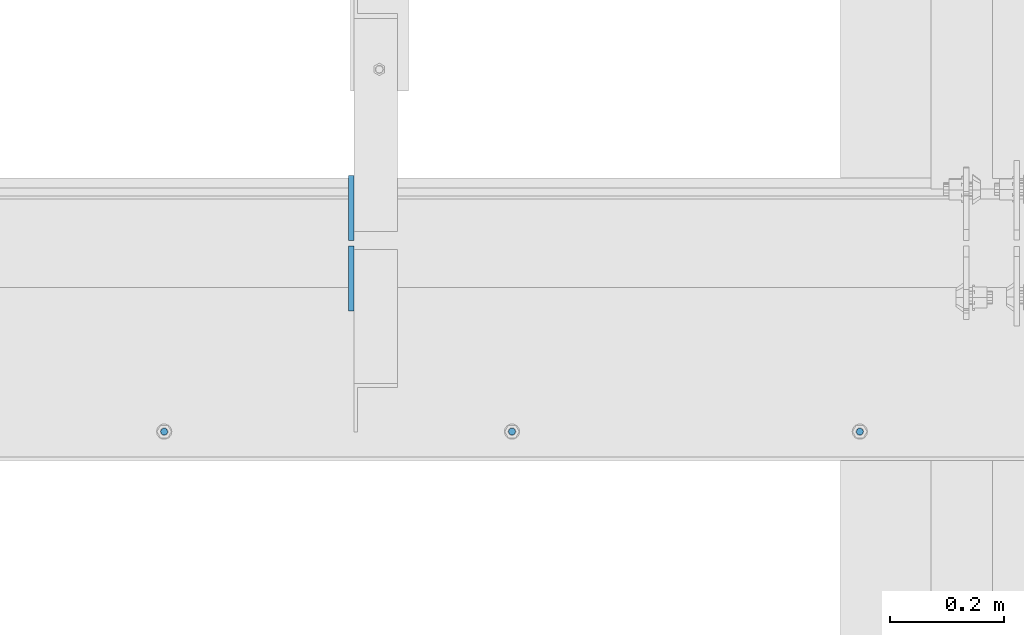
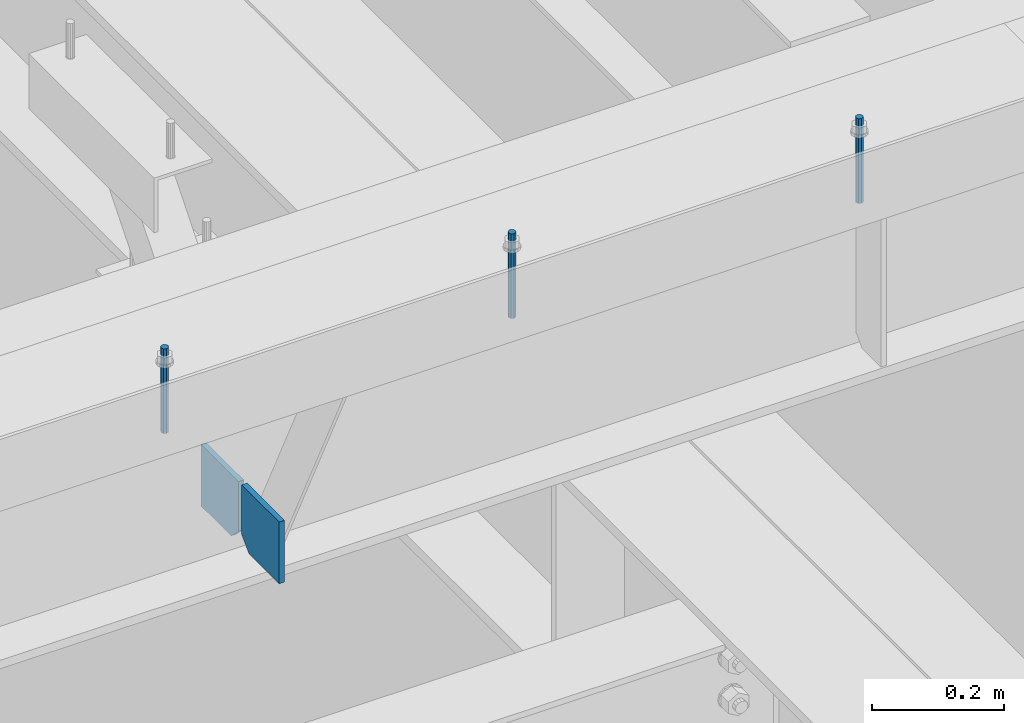
# One storey, part 458 of 1179: 5 columns, 1 element without a shape of its own.
"""IFC2X3 building model written with IfcOpenShell, lengths in millimetres."""

from ifc_helpers import new_model, si_unit, frame, origin_with_axes, place, context, subcontext, project, spatial, faceted_brep, material, type_object, element, aggregate, save


model = new_model("IFC2X3")

# Units and contexts
model_context = context("Model", 3, precision=1e-05, world=origin_with_axes())
body_context = subcontext(model_context, "Body", "Model", "MODEL_VIEW")
ifc_project = project(units=[si_unit("LENGTHUNIT", "METRE", prefix="MILLI"), si_unit("AREAUNIT", "SQUARE_METRE"), si_unit("VOLUMEUNIT", "CUBIC_METRE"), si_unit("MASSUNIT", "GRAM", prefix="KILO"), si_unit("TIMEUNIT", "SECOND"), si_unit("PLANEANGLEUNIT", "RADIAN"), si_unit("SOLIDANGLEUNIT", "STERADIAN"), si_unit("THERMODYNAMICTEMPERATUREUNIT", "DEGREE_CELSIUS"), si_unit("LUMINOUSINTENSITYUNIT", "LUMEN")], contexts=[model_context])

# Site, building, storey
site_placement = place(None, origin_with_axes())
site = spatial("IfcSite", under=ifc_project, at=site_placement, CompositionType="ELEMENT")
building_placement = place(site_placement, origin_with_axes())
building = spatial("IfcBuilding", under=site, at=building_placement, Name="Undefined", CompositionType="ELEMENT")
storey_placement = place(building_placement, origin_with_axes())
storey = spatial("IfcBuildingStorey", under=building, at=storey_placement, Name="Undefined", CompositionType="ELEMENT", Elevation=0.0)

# Assembly, columns
assembly_placement = place(storey_placement, origin_with_axes())
assembly = element("IfcElementAssembly", 1, at=assembly_placement, inside=storey, Name="BEAM", AssemblyPlace="NOTDEFINED", PredefinedType="RIGID_FRAME")
ifc_material_1 = material(Name="STEEL/A36")
column_type_1 = type_object("IfcColumnType", PredefinedType="NOTDEFINED")
column_1_placement = place(assembly_placement, frame((21240.7499995918, 27112.9125, 7496.175), z_axis=(0.0, -1.0, 0.0), x_axis=(0.0, 0.0, 1.0)))
column_1 = element("IfcColumn", 2, at=column_1_placement, type_object=column_type_1, material=ifc_material_1, Name="PLATE", context=body_context, shape_type="Brep", body=[
    faceted_brep([(22.2250000000004, 4.76250000000073, 57.1500000000015), (0.0, 4.76250000000073, 34.9249999999993), (0.0, -4.76250000000073, 34.9249999999993), (22.2250000000004, -4.76250000000073, 57.1500000000015), (114.300000000001, 4.76250000000073, 57.1500000000015), (114.300000000001, 4.76250000000073, -57.1500000000015), (0.0, 4.76250000000073, -57.1500000000015), (114.300000000001, -4.76250000000073, 57.1500000000015), (0.0, -4.76250000000073, -57.1500000000015), (114.300000000001, -4.76250000000073, -57.1500000000015)], [[[0, 1, 2, 3]], [[4, 5, 6, 1, 0]], [[7, 4, 0, 3]], [[8, 9, 7, 3, 2]], [[8, 6, 5, 9]], [[7, 9, 5, 4]], [[6, 8, 2, 1]]]),
])
column_2_placement = place(assembly_placement, frame((21240.7499995918, 26989.0875, 7496.175), z_axis=(0.0, 1.0, 0.0), x_axis=(0.0, 0.0, 1.0)))
column_2 = element("IfcColumn", 3, at=column_2_placement, type_object=column_type_1, material=ifc_material_1, Name="PLATE", context=body_context, shape_type="Brep", body=[
    faceted_brep([(22.2250000000004, 4.76250000000073, 57.1500000000015), (0.0, 4.76250000000073, 34.9249999999993), (0.0, -4.76250000000073, 34.9249999999993), (22.2250000000004, -4.76250000000073, 57.1500000000015), (114.300000000001, 4.76250000000073, 57.1500000000015), (114.300000000001, 4.76250000000073, -57.1500000000015), (0.0, 4.76250000000073, -57.1500000000015), (114.300000000001, -4.76250000000073, 57.1500000000015), (0.0, -4.76250000000073, -57.1500000000015), (114.300000000001, -4.76250000000073, -57.1500000000015)], [[[0, 1, 2, 3]], [[4, 5, 6, 1, 0]], [[7, 4, 0, 3]], [[8, 9, 7, 3, 2]], [[8, 6, 5, 9]], [[7, 9, 5, 4]], [[6, 8, 2, 1]]]),
])
ifc_material_2 = material(Name="STEEL/A307")
column_type_2 = type_object("IfcColumnType", PredefinedType="NOTDEFINED")
column_3_placement = place(assembly_placement, frame((22132.1315, 26720.8, 8020.05), z_axis=(0.0, 1.0, 0.0), x_axis=(0.0, 0.0, 1.0)))
column_3 = element("IfcColumn", 4, at=column_3_placement, type_object=column_type_2, material=ifc_material_2, Name="THREADED ROD", context=body_context, shape_type="Brep", body=[
    faceted_brep([(0.0, -6.34999999999854, 0.0), (0.0, -4.49012806053361, -4.49012806053452), (157.162499999999, -4.49012806053361, -4.49012806053361), (157.162499999999, -6.34999999999854, 0.0), (0.0, 0.0, -6.34999999999991), (157.162499999999, 0.0, -6.34999999999854), (0.0, 4.49012806053361, -4.49012806053452), (157.162499999999, 4.49012806053361, -4.49012806053361), (0.0, 6.34999999999854, 0.0), (157.162499999999, 6.34999999999854, 0.0), (0.0, 4.49012806053361, 4.49012806053452), (157.162499999999, 4.49012806053361, 4.49012806053361), (0.0, 0.0, 6.34999999999991), (157.162499999999, 0.0, 6.34999999999854), (0.0, -4.49012806053361, 4.49012806053452), (157.162499999999, -4.49012806053361, 4.49012806053361)], [[[0, 1, 2, 3]], [[1, 4, 5, 2]], [[4, 6, 7, 5]], [[6, 8, 9, 7]], [[8, 10, 11, 9]], [[10, 12, 13, 11]], [[12, 14, 15, 13]], [[14, 0, 3, 15]], [[5, 7, 9, 11, 13, 15, 3, 2]], [[14, 12, 10, 8, 6, 4, 1, 0]]]),
])
column_4_placement = place(assembly_placement, frame((21522.5315, 26720.8, 8020.05), z_axis=(0.0, 1.0, 0.0), x_axis=(0.0, 0.0, 1.0)))
column_4 = element("IfcColumn", 5, at=column_4_placement, type_object=column_type_2, material=ifc_material_2, Name="THREADED ROD", context=body_context, shape_type="Brep", body=[
    faceted_brep([(0.0, -6.34999999999854, 0.0), (0.0, -4.49012806053361, -4.49012806053452), (157.162499999999, -4.49012806053361, -4.49012806053361), (157.162499999999, -6.34999999999854, 0.0), (0.0, 0.0, -6.34999999999991), (157.162499999999, 0.0, -6.34999999999854), (0.0, 4.49012806053361, -4.49012806053452), (157.162499999999, 4.49012806053361, -4.49012806053361), (0.0, 6.34999999999854, 0.0), (157.162499999999, 6.34999999999854, 0.0), (0.0, 4.49012806053361, 4.49012806053452), (157.162499999999, 4.49012806053361, 4.49012806053361), (0.0, 0.0, 6.34999999999991), (157.162499999999, 0.0, 6.34999999999854), (0.0, -4.49012806053361, 4.49012806053452), (157.162499999999, -4.49012806053361, 4.49012806053361)], [[[0, 1, 2, 3]], [[1, 4, 5, 2]], [[4, 6, 7, 5]], [[6, 8, 9, 7]], [[8, 10, 11, 9]], [[10, 12, 13, 11]], [[12, 14, 15, 13]], [[14, 0, 3, 15]], [[5, 7, 9, 11, 13, 15, 3, 2]], [[14, 12, 10, 8, 6, 4, 1, 0]]]),
])
column_5_placement = place(assembly_placement, frame((20912.9315, 26720.8, 8020.05), z_axis=(0.0, 1.0, 0.0), x_axis=(0.0, 0.0, 1.0)))
column_5 = element("IfcColumn", 6, at=column_5_placement, type_object=column_type_2, material=ifc_material_2, Name="THREADED ROD", context=body_context, shape_type="Brep", body=[
    faceted_brep([(0.0, -6.34999999999854, 0.0), (0.0, -4.49012806053361, -4.49012806053452), (157.162499999999, -4.49012806053361, -4.49012806053361), (157.162499999999, -6.34999999999854, 0.0), (0.0, 0.0, -6.34999999999991), (157.162499999999, 0.0, -6.34999999999854), (0.0, 4.49012806053361, -4.49012806053452), (157.162499999999, 4.49012806053361, -4.49012806053361), (0.0, 6.34999999999854, 0.0), (157.162499999999, 6.34999999999854, 0.0), (0.0, 4.49012806053361, 4.49012806053452), (157.162499999999, 4.49012806053361, 4.49012806053361), (0.0, 0.0, 6.34999999999991), (157.162499999999, 0.0, 6.34999999999854), (0.0, -4.49012806053361, 4.49012806053452), (157.162499999999, -4.49012806053361, 4.49012806053361)], [[[0, 1, 2, 3]], [[1, 4, 5, 2]], [[4, 6, 7, 5]], [[6, 8, 9, 7]], [[8, 10, 11, 9]], [[10, 12, 13, 11]], [[12, 14, 15, 13]], [[14, 0, 3, 15]], [[5, 7, 9, 11, 13, 15, 3, 2]], [[14, 12, 10, 8, 6, 4, 1, 0]]]),
])
aggregate(assembly, [column_3, column_4, column_5, column_1, column_2])

save(model, "model.ifc")
